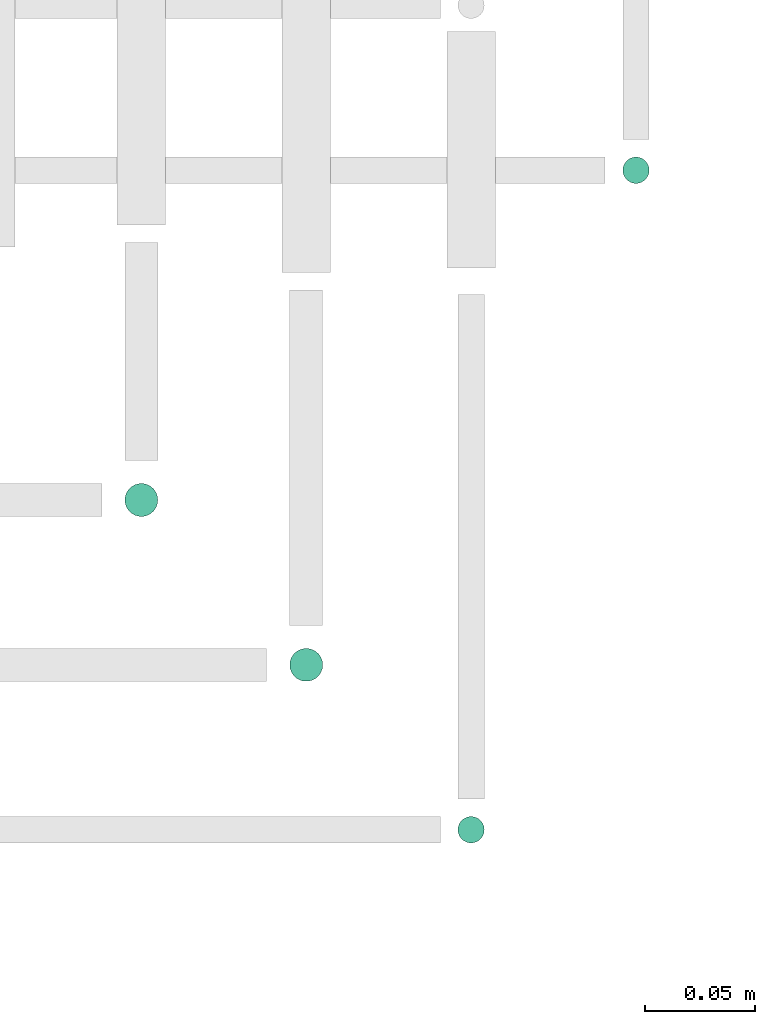
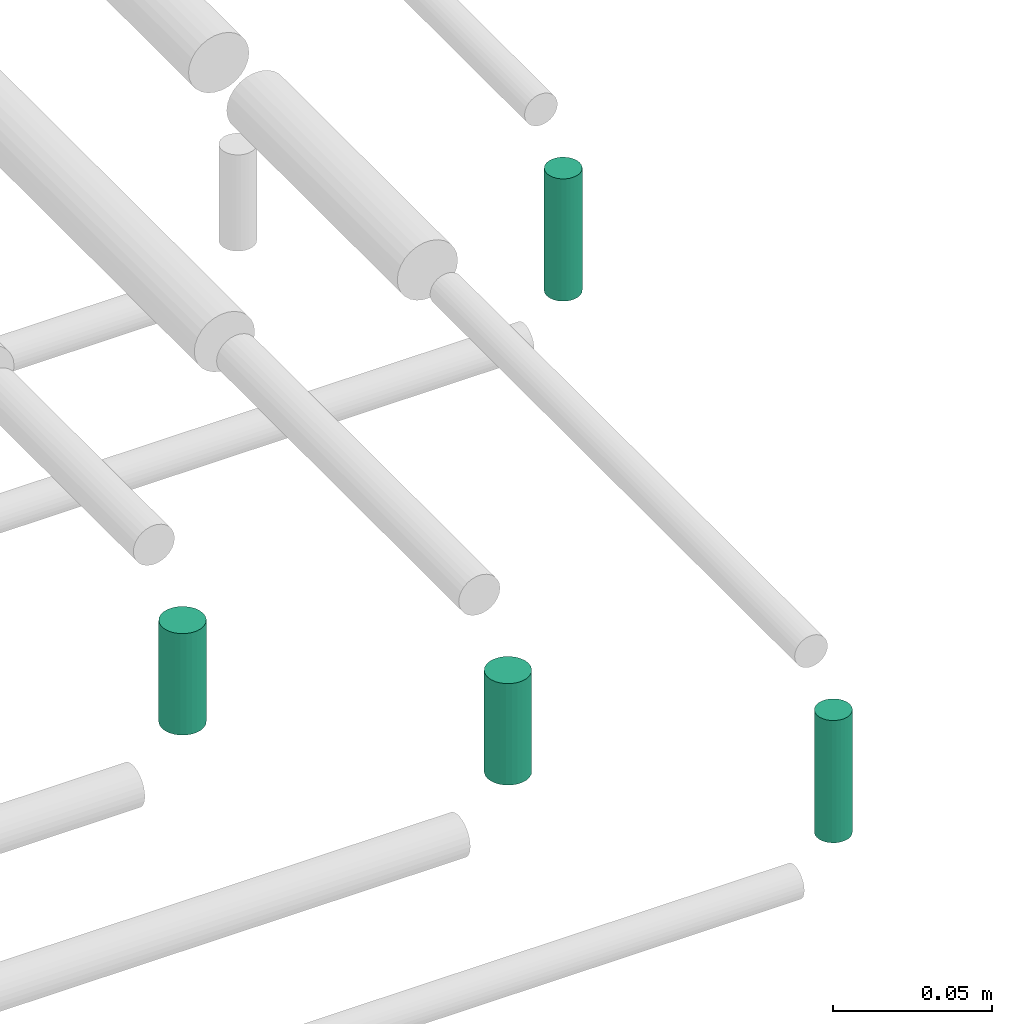
# One storey, part 58 of 65: 4 flow segments.
"""IFC2X3 building model written with IfcOpenShell, lengths in millimetres."""

from ifc_helpers import new_model, entity, si_unit, converted_unit, derived_unit, direction, frame, frame_2d, origin, origin_2d_with_axis, place, context, subcontext, project, spatial, circle, extrude, type_object, element, save


model = new_model("IFC2X3")

# Units and contexts
model_context = context("Model", 3, precision=0.01, world=origin(), true_north=direction((6.12303176911189e-17, 1.0)))
body_context = subcontext(model_context, "Body", "Model", "MODEL_VIEW")
ifc_project = project(units=[si_unit("LENGTHUNIT", "METRE", prefix="MILLI"), si_unit("AREAUNIT", "SQUARE_METRE"), si_unit("VOLUMEUNIT", "CUBIC_METRE"), converted_unit("PLANEANGLEUNIT", "DEGREE", entity("IfcRatioMeasure", 0.0174532925199433), si_unit("PLANEANGLEUNIT", "RADIAN"), dimensions=[0, 0, 0, 0, 0, 0, 0]), si_unit("MASSUNIT", "GRAM", prefix="KILO"), derived_unit("MASSDENSITYUNIT", [(si_unit("MASSUNIT", "GRAM", prefix="KILO"), 1), (si_unit("LENGTHUNIT", "METRE"), -3)]), derived_unit("MOMENTOFINERTIAUNIT", [(si_unit("LENGTHUNIT", "METRE"), 4)]), si_unit("TIMEUNIT", "SECOND"), si_unit("FREQUENCYUNIT", "HERTZ"), si_unit("THERMODYNAMICTEMPERATUREUNIT", "DEGREE_CELSIUS"), derived_unit("THERMALTRANSMITTANCEUNIT", [(si_unit("MASSUNIT", "GRAM", prefix="KILO"), 1), (si_unit("THERMODYNAMICTEMPERATUREUNIT", "KELVIN"), -1), (si_unit("TIMEUNIT", "SECOND"), -3)]), derived_unit("VOLUMETRICFLOWRATEUNIT", [(si_unit("LENGTHUNIT", "METRE"), 3), (si_unit("TIMEUNIT", "SECOND"), -1)]), derived_unit("MASSFLOWRATEUNIT", [(si_unit("MASSUNIT", "GRAM", prefix="KILO"), 1), (si_unit("TIMEUNIT", "SECOND"), -1)]), derived_unit("ROTATIONALFREQUENCYUNIT", [(si_unit("TIMEUNIT", "SECOND"), -1)]), si_unit("ELECTRICCURRENTUNIT", "AMPERE"), si_unit("ELECTRICVOLTAGEUNIT", "VOLT"), si_unit("POWERUNIT", "WATT"), si_unit("FORCEUNIT", "NEWTON", prefix="KILO"), si_unit("ILLUMINANCEUNIT", "LUX"), si_unit("LUMINOUSFLUXUNIT", "LUMEN"), si_unit("LUMINOUSINTENSITYUNIT", "CANDELA"), derived_unit("USERDEFINED", [(si_unit("MASSUNIT", "GRAM", prefix="KILO"), -1), (si_unit("LENGTHUNIT", "METRE"), -2), (si_unit("TIMEUNIT", "SECOND"), 3), (si_unit("LUMINOUSFLUXUNIT", "LUMEN"), 1)]), derived_unit("LINEARVELOCITYUNIT", [(si_unit("LENGTHUNIT", "METRE"), 1), (si_unit("TIMEUNIT", "SECOND"), -1)]), si_unit("PRESSUREUNIT", "PASCAL"), derived_unit("USERDEFINED", [(si_unit("LENGTHUNIT", "METRE"), -2), (si_unit("MASSUNIT", "GRAM", prefix="KILO"), 1), (si_unit("TIMEUNIT", "SECOND"), -2)]), derived_unit("LINEARFORCEUNIT", [(si_unit("MASSUNIT", "GRAM", prefix="KILO"), 1), (si_unit("LENGTHUNIT", "METRE"), 1), (si_unit("TIMEUNIT", "SECOND"), -2), (si_unit("LENGTHUNIT", "METRE"), -1)]), derived_unit("PLANARFORCEUNIT", [(si_unit("MASSUNIT", "GRAM", prefix="KILO"), 1), (si_unit("LENGTHUNIT", "METRE"), 1), (si_unit("TIMEUNIT", "SECOND"), -2), (si_unit("LENGTHUNIT", "METRE"), -2)])], contexts=[model_context])

# Site, building, storey
site_placement = place(None, frame((0.0, -0.00077364408347762, 0.0)))
site = spatial("IfcSite", under=ifc_project, at=site_placement, CompositionType="ELEMENT")
building_placement = place(site_placement, origin())
building = spatial("IfcBuilding", under=site, at=building_placement, CompositionType="ELEMENT")
storey_placement = place(building_placement, frame((0.0, 0.0, 19800.0)))
storey = spatial("IfcBuildingStorey", under=building, at=storey_placement, CompositionType="ELEMENT", Elevation=19800.0)

# Flow segments
pipe_segment_type = type_object("IfcPipeSegmentType", PredefinedType="NOTDEFINED")
flow_segment_1_placement = place(storey_placement, frame((63775.9640720084, 8165.90493375772, 2493.0)))
element("IfcFlowSegment", 1, at=flow_segment_1_placement, inside=storey, type_object=pipe_segment_type, context=body_context, shape_type="SweptSolid", body=[
    extrude(circle(Radius=7.5, at=origin_2d_with_axis()), frame((9.09527223591419, 9.09527223591636, 0.0)), (0.0, 0.0, 1.0), 38.9999999999435),
])
flow_segment_2_placement = place(storey_placement, frame((63850.9640720084, 8090.90493375772, 2493.0)))
element("IfcFlowSegment", 2, at=flow_segment_2_placement, inside=storey, type_object=pipe_segment_type, context=body_context, shape_type="SweptSolid", body=[
    extrude(circle(Radius=7.5, at=origin_2d_with_axis()), frame((9.09527223591419, 9.09527223591636, 0.0)), (0.0, 0.0, 1.0), 38.9999999999695),
])
flow_segment_3_placement = place(storey_placement, frame((63927.4640720084, 8017.40493375772, 2489.0)))
element("IfcFlowSegment", 3, at=flow_segment_3_placement, inside=storey, type_object=pipe_segment_type, context=body_context, shape_type="SweptSolid", body=[
    extrude(circle(Radius=6.0, at=origin_2d_with_axis()), frame((7.59527223591454, 7.59527223591562, 0.0)), (0.0, 0.0, 1.0), 47.0000000000196),
])
flow_segment_4_placement = place(storey_placement, frame((64002.4640720084, 8317.40493375779, 2489.0)))
element("IfcFlowSegment", 4, at=flow_segment_4_placement, inside=storey, type_object=pipe_segment_type, context=body_context, shape_type="SweptSolid", body=[
    extrude(circle(Radius=6.0, at=frame_2d((0.0, -1.08286712929839e-12), x_axis=(1.0, 0.0))), frame((7.59527223591454, 7.5952722359167, 0.0)), (0.0, 0.0, 1.0), 46.999999999959),
])

save(model, "model.ifc")
